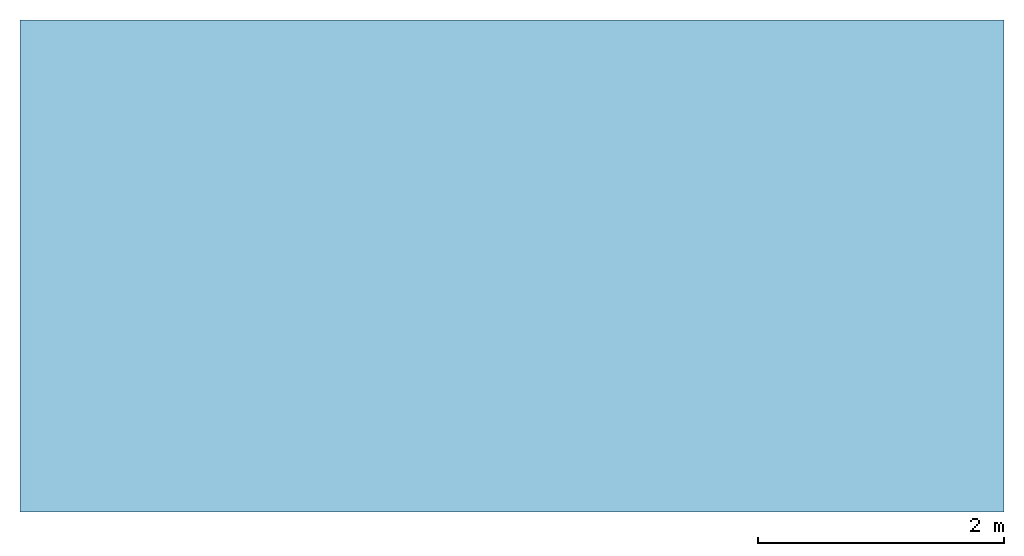
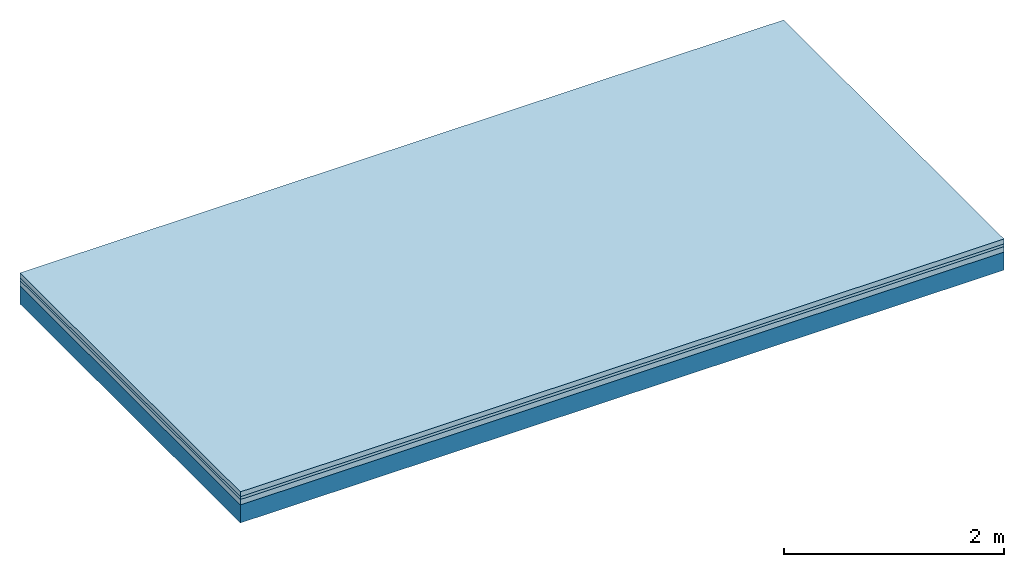
# One storey: 3 plates, 1 member, 1 element without a shape of its own.
"""IFC4 building model written with IfcOpenShell, lengths in metres."""

from ifc_helpers import new_model, si_unit, derived_unit, direction, frame, frame_2d, origin, origin_with_axes, place, context, project, spatial, rectangle, extrude, material, layer, layer_set, type_object, element, aggregate, save


model = new_model("IFC4")

# Units and contexts
plan_context = context("Plan", 3, precision=1e-05, world=origin(), true_north=direction((0.0, 1.0)))
model_context = context("Model", 3, precision=1e-05, world=origin(), true_north=direction((0.0, 1.0)))
ifc_project = project(units=[si_unit("LENGTHUNIT", "METRE"), derived_unit("SOUNDPRESSUREUNIT", [(si_unit("PRESSUREUNIT", "PASCAL", prefix="MICRO"), 0)]), si_unit("ENERGYUNIT", "JOULE", prefix="MEGA"), si_unit("MASSUNIT", "GRAM", prefix="KILO"), derived_unit("THERMALTRANSMITTANCEUNIT", [(si_unit("POWERUNIT", "WATT"), 1), (si_unit("AREAUNIT", "SQUARE_METRE"), -1), (si_unit("THERMODYNAMICTEMPERATUREUNIT", "KELVIN"), -1)]), derived_unit("AREADENSITYUNIT", [(si_unit("MASSUNIT", "GRAM", prefix="KILO"), 1), (si_unit("AREAUNIT", "SQUARE_METRE"), -1)]), derived_unit("USERDEFINED", [(si_unit("ENERGYUNIT", "JOULE", prefix="MEGA"), 1), (si_unit("AREAUNIT", "SQUARE_METRE"), -1)])], contexts=[plan_context, model_context])

# Site, building, storey
site = spatial("IfcSite", under=ifc_project)
building_placement = place(None, origin())
building = spatial("IfcBuilding", under=site, at=building_placement)
storey_placement = place(building_placement, origin())
storey = spatial("IfcBuildingStorey", under=building, at=storey_placement)

# Slab, member, plates
ifc_material_1 = material(Category="04.005")
ifc_layer_1 = layer(ifc_material_1, 0.055, Name="On-material")
ifc_material_2 = material()
ifc_layer_2 = layer(ifc_material_2, 0.03, Name="Impact sound insulation")
ifc_material_3 = material(Category="03.011")
ifc_layer_3 = layer(ifc_material_3, 0.06, Name="on Supporting structure")
ifc_layer_4 = layer(None, 0.2, Name="Supporting structure")
ifc_layer_set = layer_set([ifc_layer_1, ifc_layer_2, ifc_layer_3, ifc_layer_4])
slab_type = type_object("IfcSlabType", Name="A1090", PredefinedType="NOTDEFINED", material=ifc_layer_set)
slab_placement = place(None, frame((0.0, 0.0, 0.0), z_axis=(0.0, 0.0, -1.0), x_axis=(1.0, 0.0, 0.0)))
slab = element("IfcSlab", 1, at=slab_placement, inside=storey, type_object=slab_type, material=ifc_layer_set, Name="Slab #1")
ifc_material_4 = material()
member_placement = place(slab_placement, origin())
member = element("IfcMember", 2, at=member_placement, material=ifc_material_4, Name="Supporting structure", context=plan_context, shape_type="SweptSolid", body=[
    extrude(rectangle(XDim=1.0, YDim=0.2, at=frame_2d((0.5, 0.1), x_axis=(1.0, 0.0))), frame((0.0, 4.0, 0.145), z_axis=(0.0, -1.0, 0.0), x_axis=(1.0, 0.0, 0.0)), (0.0, 0.0, 1.0), 4.0),
    extrude(rectangle(XDim=1.0, YDim=0.2, at=frame_2d((0.5, 0.1), x_axis=(1.0, 0.0))), frame((1.0, 4.0, 0.145), z_axis=(0.0, -1.0, 0.0), x_axis=(1.0, 0.0, 0.0)), (0.0, 0.0, 1.0), 4.0),
    extrude(rectangle(XDim=1.0, YDim=0.2, at=frame_2d((0.5, 0.1), x_axis=(1.0, 0.0))), frame((2.0, 4.0, 0.145), z_axis=(0.0, -1.0, 0.0), x_axis=(1.0, 0.0, 0.0)), (0.0, 0.0, 1.0), 4.0),
    extrude(rectangle(XDim=1.0, YDim=0.2, at=frame_2d((0.5, 0.1), x_axis=(1.0, 0.0))), frame((3.0, 4.0, 0.145), z_axis=(0.0, -1.0, 0.0), x_axis=(1.0, 0.0, 0.0)), (0.0, 0.0, 1.0), 4.0),
    extrude(rectangle(XDim=1.0, YDim=0.2, at=frame_2d((0.5, 0.1), x_axis=(1.0, 0.0))), frame((4.0, 4.0, 0.145), z_axis=(0.0, -1.0, 0.0), x_axis=(1.0, 0.0, 0.0)), (0.0, 0.0, 1.0), 4.0),
    extrude(rectangle(XDim=1.0, YDim=0.2, at=frame_2d((0.5, 0.1), x_axis=(1.0, 0.0))), frame((5.0, 4.0, 0.145), z_axis=(0.0, -1.0, 0.0), x_axis=(1.0, 0.0, 0.0)), (0.0, 0.0, 1.0), 4.0),
    extrude(rectangle(XDim=1.0, YDim=0.2, at=frame_2d((0.5, 0.1), x_axis=(1.0, 0.0))), frame((6.0, 4.0, 0.145), z_axis=(0.0, -1.0, 0.0), x_axis=(1.0, 0.0, 0.0)), (0.0, 0.0, 1.0), 4.0),
    extrude(rectangle(XDim=1.0, YDim=0.2, at=frame_2d((0.5, 0.1), x_axis=(1.0, 0.0))), frame((7.0, 4.0, 0.145), z_axis=(0.0, -1.0, 0.0), x_axis=(1.0, 0.0, 0.0)), (0.0, 0.0, 1.0), 4.0),
])
plate_1_placement = place(slab_placement, origin())
plate_1 = element("IfcPlate", 3, at=plate_1_placement, material=ifc_material_1, Name="On-material", context=plan_context, shape_type="SweptSolid", body=[
    extrude(rectangle(XDim=8.0, YDim=4.0, at=frame_2d((4.0, 2.0), x_axis=(1.0, 0.0))), origin_with_axes(), (0.0, 0.0, 1.0), 0.055),
])
plate_2_placement = place(slab_placement, origin())
plate_2 = element("IfcPlate", 4, at=plate_2_placement, material=ifc_material_2, Name="Impact sound insulation", context=plan_context, shape_type="SweptSolid", body=[
    extrude(rectangle(XDim=8.0, YDim=4.0, at=frame_2d((4.0, 2.0), x_axis=(1.0, 0.0))), frame((0.0, 0.0, 0.055), z_axis=(0.0, 0.0, 1.0), x_axis=(1.0, 0.0, 0.0)), (0.0, 0.0, 1.0), 0.03),
])
plate_3_placement = place(slab_placement, origin())
plate_3 = element("IfcPlate", 5, at=plate_3_placement, material=ifc_material_3, Name="on Supporting structure", context=plan_context, shape_type="SweptSolid", body=[
    extrude(rectangle(XDim=8.0, YDim=4.0, at=frame_2d((4.0, 2.0), x_axis=(1.0, 0.0))), frame((0.0, 0.0, 0.085), z_axis=(0.0, 0.0, 1.0), x_axis=(1.0, 0.0, 0.0)), (0.0, 0.0, 1.0), 0.06),
])
aggregate(slab, [plate_1, plate_2, plate_3, member])

save(model, "model.ifc")
